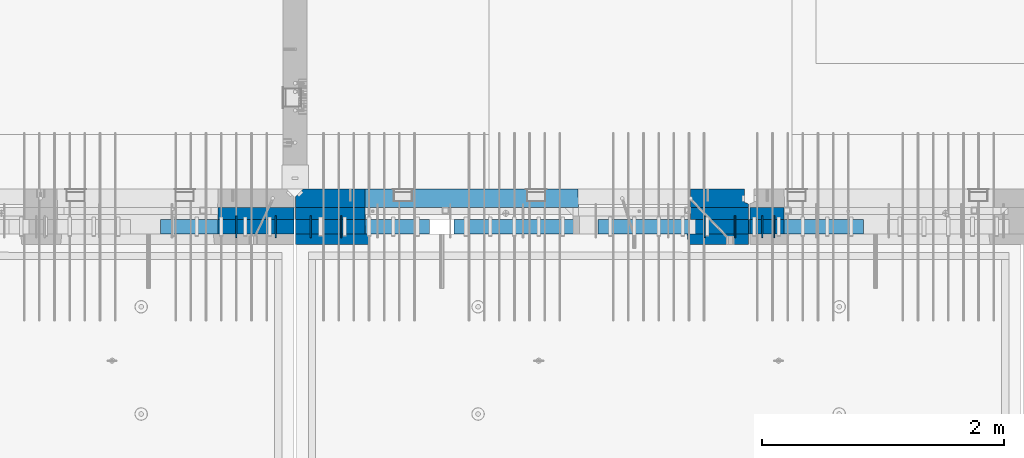
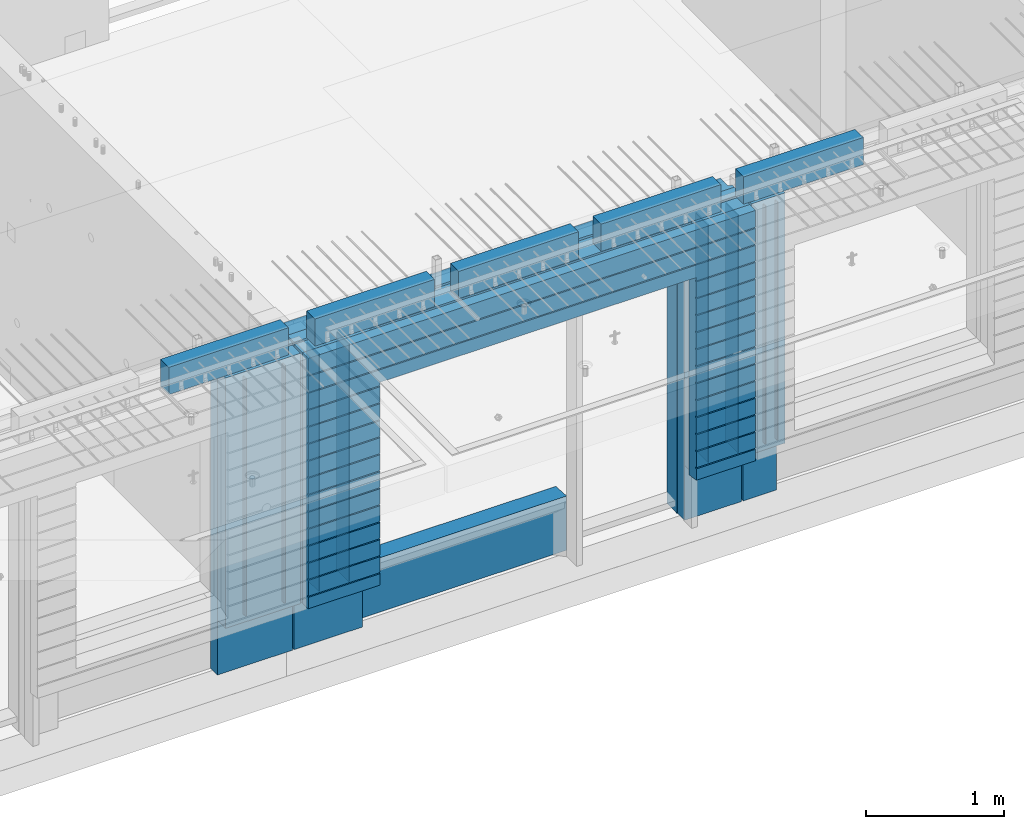
# One storey, part 211 of 325: 24 walls, 10 elements without a shape of their own.
"""IFC2X3 building model written with IfcOpenShell, lengths in millimetres."""

from ifc_helpers import new_model, si_unit, frame, origin_with_axes, place, context, subcontext, project, spatial, faceted_brep, material, type_object, element, aggregate, save


model = new_model("IFC2X3")

# Units and contexts
model_context = context("Model", 3, precision=1e-05, world=origin_with_axes())
body_context = subcontext(model_context, "Body", "Model", "MODEL_VIEW")
ifc_project = project(units=[si_unit("LENGTHUNIT", "METRE", prefix="MILLI"), si_unit("AREAUNIT", "SQUARE_METRE"), si_unit("VOLUMEUNIT", "CUBIC_METRE"), si_unit("MASSUNIT", "GRAM", prefix="KILO"), si_unit("TIMEUNIT", "SECOND"), si_unit("PLANEANGLEUNIT", "RADIAN"), si_unit("SOLIDANGLEUNIT", "STERADIAN"), si_unit("THERMODYNAMICTEMPERATUREUNIT", "DEGREE_CELSIUS"), si_unit("LUMINOUSINTENSITYUNIT", "LUMEN")], contexts=[model_context])

# Site, building, storey
site_placement = place(None, origin_with_axes())
site = spatial("IfcSite", under=ifc_project, at=site_placement, CompositionType="ELEMENT")
building_placement = place(site_placement, origin_with_axes())
building = spatial("IfcBuilding", under=site, at=building_placement, CompositionType="ELEMENT")
storey_placement = place(building_placement, origin_with_axes())
storey = spatial("IfcBuildingStorey", under=building, at=storey_placement, Name="1", CompositionType="ELEMENT", Elevation=0.0)

# Assemblies, wall
assembly_1_placement = place(storey_placement, origin_with_axes())
assembly_1 = element("IfcElementAssembly", 1, at=assembly_1_placement, inside=storey, AssemblyPlace="NOTDEFINED", PredefinedType="REINFORCEMENT_UNIT")
assembly_2_placement = place(assembly_1_placement, origin_with_axes())
assembly_2 = element("IfcElementAssembly", 2, at=assembly_2_placement, Name="Steel Assembly", AssemblyPlace="NOTDEFINED", PredefinedType="NOTDEFINED")
aggregate(assembly_1, [assembly_2])
ifc_material_1 = material()
wall_type_1 = type_object("IfcWallType", PredefinedType="NOTDEFINED")
wall_1_placement = place(assembly_2_placement, frame((20699.9998568133, 7690.00021946163, 84590.0), z_axis=(0.0, 0.0, 1.0), x_axis=(1.0, 0.0, 0.0)))
wall_1 = element("IfcWall", 3, at=wall_1_placement, type_object=wall_type_1, material=ifc_material_1, context=body_context, shape_type="Brep", body=[
    faceted_brep([(0.0, 60.0, -120.0), (0.0, 60.0, 120.0), (1000.0, 60.0, 120.0), (1000.0, 60.0, -120.0), (0.0, -60.0, 120.0), (1000.0, -60.0, 120.0), (0.0, -60.0, -120.0), (1000.0, -60.0, -120.0)], [[[0, 1, 2, 3]], [[1, 4, 5, 2]], [[4, 6, 7, 5]], [[6, 0, 3, 7]], [[5, 7, 3, 2]], [[6, 4, 1, 0]]]),
])
aggregate(assembly_2, [wall_1])

# Assemblies, walls
assembly_3_placement = place(storey_placement, origin_with_axes())
assembly_3 = element("IfcElementAssembly", 4, at=assembly_3_placement, inside=storey, AssemblyPlace="NOTDEFINED", PredefinedType="REINFORCEMENT_UNIT")
assembly_4_placement = place(assembly_3_placement, origin_with_axes())
assembly_4 = element("IfcElementAssembly", 5, at=assembly_4_placement, Name="Steel Assembly", AssemblyPlace="NOTDEFINED", PredefinedType="NOTDEFINED")
wall_2_placement = place(assembly_4_placement, frame((25499.9998568133, 7690.00021946163, 84590.0), z_axis=(0.0, 0.0, 1.0), x_axis=(1.0, 0.0, 0.0)))
wall_2 = element("IfcWall", 6, at=wall_2_placement, type_object=wall_type_1, material=ifc_material_1, context=body_context, shape_type="Brep", body=[
    faceted_brep([(0.0, 60.0, -120.0), (0.0, 60.0, 120.0), (1000.0, 60.0, 120.0), (1000.0, 60.0, -120.0), (0.0, -60.0, 120.0), (1000.0, -60.0, 120.0), (0.0, -60.0, -120.0), (1000.0, -60.0, -120.0)], [[[0, 1, 2, 3]], [[1, 4, 5, 2]], [[4, 6, 7, 5]], [[6, 0, 3, 7]], [[5, 7, 3, 2]], [[6, 4, 1, 0]]]),
])
aggregate(assembly_4, [wall_2])
assembly_5_placement = place(assembly_3_placement, origin_with_axes())
assembly_5 = element("IfcElementAssembly", 7, at=assembly_5_placement, Name="Steel Assembly", AssemblyPlace="NOTDEFINED", PredefinedType="NOTDEFINED")
wall_3_placement = place(assembly_5_placement, frame((24309.9998568133, 7690.00021946163, 84590.0), z_axis=(0.0, 0.0, 1.0), x_axis=(1.0, 0.0, 0.0)))
wall_3 = element("IfcWall", 8, at=wall_3_placement, type_object=wall_type_1, material=ifc_material_1, context=body_context, shape_type="Brep", body=[
    faceted_brep([(0.0, 60.0, -120.0), (0.0, 60.0, 120.0), (1000.0, 60.0, 120.0), (1000.0, 60.0, -120.0), (0.0, -60.0, 120.0), (1000.0, -60.0, 120.0), (0.0, -60.0, -120.0), (1000.0, -60.0, -120.0)], [[[0, 1, 2, 3]], [[1, 4, 5, 2]], [[4, 6, 7, 5]], [[6, 0, 3, 7]], [[5, 7, 3, 2]], [[6, 4, 1, 0]]]),
])
aggregate(assembly_5, [wall_3])
assembly_6_placement = place(assembly_3_placement, origin_with_axes())
assembly_6 = element("IfcElementAssembly", 9, at=assembly_6_placement, Name="Steel Assembly", AssemblyPlace="NOTDEFINED", PredefinedType="NOTDEFINED")
wall_4_placement = place(assembly_6_placement, frame((23119.9998568133, 7690.00021946163, 84590.0), z_axis=(0.0, 0.0, 1.0), x_axis=(1.0, 0.0, 0.0)))
wall_4 = element("IfcWall", 10, at=wall_4_placement, type_object=wall_type_1, material=ifc_material_1, context=body_context, shape_type="Brep", body=[
    faceted_brep([(0.0, 60.0, -120.0), (0.0, 60.0, 120.0), (1000.0, 60.0, 120.0), (1000.0, 60.0, -120.0), (0.0, -60.0, 120.0), (1000.0, -60.0, 120.0), (0.0, -60.0, -120.0), (1000.0, -60.0, -120.0)], [[[0, 1, 2, 3]], [[1, 4, 5, 2]], [[4, 6, 7, 5]], [[6, 0, 3, 7]], [[5, 7, 3, 2]], [[6, 4, 1, 0]]]),
])
aggregate(assembly_6, [wall_4])
assembly_7_placement = place(assembly_3_placement, origin_with_axes())
assembly_7 = element("IfcElementAssembly", 11, at=assembly_7_placement, Name="Steel Assembly", AssemblyPlace="NOTDEFINED", PredefinedType="NOTDEFINED")
aggregate(assembly_3, [assembly_7, assembly_6, assembly_5, assembly_4])
wall_5_placement = place(assembly_7_placement, frame((21919.9998568133, 7690.00021946163, 84590.0), z_axis=(0.0, 0.0, 1.0), x_axis=(1.0, 0.0, 0.0)))
wall_5 = element("IfcWall", 12, at=wall_5_placement, type_object=wall_type_1, material=ifc_material_1, context=body_context, shape_type="Brep", body=[
    faceted_brep([(0.0, 60.0, -120.0), (0.0, 60.0, 120.0), (1000.0, 60.0, 120.0), (1000.0, 60.0, -120.0), (0.0, -60.0, 120.0), (1000.0, -60.0, 120.0), (0.0, -60.0, -120.0), (1000.0, -60.0, -120.0)], [[[0, 1, 2, 3]], [[1, 4, 5, 2]], [[4, 6, 7, 5]], [[6, 0, 3, 7]], [[5, 7, 3, 2]], [[6, 4, 1, 0]]]),
])
aggregate(assembly_7, [wall_5])

# Assembly, wall
assembly_8_placement = place(storey_placement, origin_with_axes())
assembly_8 = element("IfcElementAssembly", 13, at=assembly_8_placement, inside=storey, AssemblyPlace="NOTDEFINED", PredefinedType="REINFORCEMENT_UNIT")
ifc_material_2 = material(Name="CONCRETE/C35/45")
wall_type_2 = type_object("IfcWallType", PredefinedType="NOTDEFINED")
wall_6_placement = place(assembly_8_placement, frame((25550.0, 7925.0, 83112.5), z_axis=(0.0, 0.0, 1.0), x_axis=(-1.0, 3.00000001838171e-08, 0.0)))
wall_6 = element("IfcWall", 14, at=wall_6_placement, type_object=wall_type_2, material=ifc_material_2, context=body_context, shape_type="Brep", body=[
    faceted_brep([(0.0, 75.0, 1357.5), (0.0, 75.0, -1357.5), (0.0, 45.0, -1357.5), (0.0, 45.0, 1357.5), (475.000517197066, -75.0, -1357.5), (478.846671043222, 75.0, -1357.5), (478.846671043219, 75.0, 948.653846153844), (475.000517197066, -75.0, 952.5), (32.5, -75.0, -1357.5), (32.5, 32.0, -1357.5), (32.5, -75.0, 1357.5), (32.5, 32.0, 1357.5), (3675.0, -75.0, 1357.5), (3735.0, -15.0, 1357.5), (3735.0, 75.0, 1357.5), (3735.0, 75.0, -1357.5), (3735.0, -15.0, -1357.5), (3675.0, -75.0, -1357.5), (1405.00051719707, -75.0, -1357.5), (1401.15436335091, 75.0, -1357.5), (1405.00051719707, -75.0, -882.5), (1401.15436335091, 75.0, -878.445945945947), (1334.05403802673, 75.0, 948.653846153844), (3160.9460816706, 75.0, -878.445945945947), (3160.9460816706, 75.0, 948.445945945947), (1401.15436335091, 75.0, 948.653846153844), (1330.00013572465, -75.0, 952.5), (1405.00051719707, -75.0, 952.5), (3165.00013572465, -75.0, -882.5), (3165.00013572465, -75.0, 952.5)], [[[0, 1, 2, 3]], [[4, 5, 6, 7]], [[8, 9, 2, 1, 5, 4]], [[10, 11, 9, 8]], [[3, 2, 9, 11]], [[10, 12, 13, 14, 0, 3, 11]], [[15, 14, 13, 16]], [[12, 17, 16, 13]], [[15, 16, 17, 18, 19]], [[19, 18, 20, 21]], [[22, 6, 5, 1, 0, 14, 15, 19, 21, 23, 24, 25]], [[26, 7, 6, 22, 25, 27]], [[28, 20, 18, 17, 12, 10, 8, 4, 7, 26, 27, 29]], [[25, 24, 29, 27]], [[23, 28, 29, 24]], [[21, 20, 28, 23]]]),
])

# Assembly, walls
assembly_9_placement = place(storey_placement, origin_with_axes())
assembly_9 = element("IfcElementAssembly", 15, at=assembly_9_placement, inside=storey, AssemblyPlace="NOTDEFINED", PredefinedType="REINFORCEMENT_UNIT")
ifc_material_3 = material(Name="Undefined")
wall_type_3 = type_object("IfcWallType", PredefinedType="NOTDEFINED")
wall_7_placement = place(assembly_9_placement, frame((25665.0, 7780.0, 83365.0), z_axis=(0.0, 0.0, 1.0), x_axis=(0.0, -1.0, 0.0)))
wall_7 = element("IfcWall", 16, at=wall_7_placement, type_object=wall_type_3, material=ifc_material_3, Name="(PD)", context=body_context, shape_type="Brep", body=[
    faceted_brep([(0.0, 5.0, -1050.0), (0.0, 5.0, 1050.0), (180.0, 5.0, 1050.0), (180.0, 5.0, -1050.0), (0.0, -5.0, 1050.0), (180.0, -5.0, 1050.0), (0.0, -5.0, -1050.0), (180.0, -5.0, -1050.0)], [[[0, 1, 2, 3]], [[1, 4, 5, 2]], [[4, 6, 7, 5]], [[6, 0, 3, 7]], [[5, 7, 3, 2]], [[6, 4, 1, 0]]]),
])
wall_8_placement = place(assembly_9_placement, frame((25765.0, 7780.0, 83365.0), z_axis=(0.0, 0.0, 1.0), x_axis=(0.0, -1.0, 0.0)))
wall_8 = element("IfcWall", 17, at=wall_8_placement, type_object=wall_type_3, material=ifc_material_3, Name="(PD)", context=body_context, shape_type="Brep", body=[
    faceted_brep([(0.0, 5.0, -1050.0), (0.0, 5.0, 1050.0), (180.0, 5.0, 1050.0), (180.0, 5.0, -1050.0), (0.0, -5.0, 1050.0), (180.0, -5.0, 1050.0), (0.0, -5.0, -1050.0), (180.0, -5.0, -1050.0)], [[[0, 1, 2, 3]], [[1, 4, 5, 2]], [[4, 6, 7, 5]], [[6, 0, 3, 7]], [[5, 7, 3, 2]], [[6, 4, 1, 0]]]),
])

assembly_10_placement = place(storey_placement, origin_with_axes())
assembly_10 = element("IfcElementAssembly", 18, at=assembly_10_placement, inside=storey, AssemblyPlace="NOTDEFINED", PredefinedType="REINFORCEMENT_UNIT")
wall_9_placement = place(assembly_10_placement, frame((21325.0, 7780.0, 83365.0), z_axis=(0.0, 0.0, 1.0), x_axis=(0.0, -1.0, 0.0)))
wall_9 = element("IfcWall", 19, at=wall_9_placement, type_object=wall_type_3, material=ifc_material_3, Name="(PD)", context=body_context, shape_type="Brep", body=[
    faceted_brep([(0.0, 5.0, -1050.0), (0.0, 5.0, 1050.0), (180.0, 5.0, 1050.0), (180.0, 5.0, -1050.0), (0.0, -5.0, 1050.0), (180.0, -5.0, 1050.0), (0.0, -5.0, -1050.0), (180.0, -5.0, -1050.0)], [[[0, 1, 2, 3]], [[1, 4, 5, 2]], [[4, 6, 7, 5]], [[6, 0, 3, 7]], [[5, 7, 3, 2]], [[6, 4, 1, 0]]]),
])
wall_10_placement = place(assembly_10_placement, frame((21650.0, 7780.0, 83365.0), z_axis=(0.0, 0.0, 1.0), x_axis=(0.0, -1.0, 0.0)))
wall_10 = element("IfcWall", 20, at=wall_10_placement, type_object=wall_type_3, material=ifc_material_3, Name="(PD)", context=body_context, shape_type="Brep", body=[
    faceted_brep([(0.0, 5.0, -1050.0), (0.0, 5.0, 1050.0), (180.0, 5.0, 1050.0), (180.0, 5.0, -1050.0), (0.0, -5.0, 1050.0), (180.0, -5.0, 1050.0), (0.0, -5.0, -1050.0), (180.0, -5.0, -1050.0)], [[[0, 1, 2, 3]], [[1, 4, 5, 2]], [[4, 6, 7, 5]], [[6, 0, 3, 7]], [[5, 7, 3, 2]], [[6, 4, 1, 0]]]),
])

# Wall
wall_11_placement = place(assembly_8_placement, frame((25190.0, 7780.0, 83365.0), z_axis=(0.0, 0.0, 1.0), x_axis=(0.0, -1.0, 0.0)))
wall_11 = element("IfcWall", 21, at=wall_11_placement, type_object=wall_type_3, material=ifc_material_3, Name="(PD)", context=body_context, shape_type="Brep", body=[
    faceted_brep([(0.0, 5.0, -1050.0), (0.0, 5.0, 1050.0), (180.0, 5.0, 1050.0), (180.0, 5.0, -1050.0), (0.0, -5.0, 1050.0), (180.0, -5.0, 1050.0), (0.0, -5.0, -1050.0), (180.0, -5.0, -1050.0)], [[[0, 1, 2, 3]], [[1, 4, 5, 2]], [[4, 6, 7, 5]], [[6, 0, 3, 7]], [[5, 7, 3, 2]], [[6, 4, 1, 0]]]),
])

wall_12_placement = place(assembly_8_placement, frame((22190.0, 7780.0, 83365.0), z_axis=(0.0, 0.0, 1.0), x_axis=(0.0, -1.0, 0.0)))
wall_12 = element("IfcWall", 22, at=wall_12_placement, type_object=wall_type_3, material=ifc_material_3, Name="(PD)", context=body_context, shape_type="Brep", body=[
    faceted_brep([(0.0, 5.0, -1050.0), (0.0, 5.0, 1050.0), (180.0, 5.0, 1050.0), (180.0, 5.0, -1050.0), (0.0, -5.0, 1050.0), (180.0, -5.0, 1050.0), (0.0, -5.0, -1050.0), (180.0, -5.0, -1050.0)], [[[0, 1, 2, 3]], [[1, 4, 5, 2]], [[4, 6, 7, 5]], [[6, 0, 3, 7]], [[5, 7, 3, 2]], [[6, 4, 1, 0]]]),
])

wall_13_placement = place(assembly_8_placement, frame((21940.0, 7780.0, 83365.0), z_axis=(0.0, 0.0, 1.0), x_axis=(0.0, -1.0, 0.0)))
wall_13 = element("IfcWall", 23, at=wall_13_placement, type_object=wall_type_3, material=ifc_material_3, Name="(PD)", context=body_context, shape_type="Brep", body=[
    faceted_brep([(0.0, 5.0, -1050.0), (0.0, 5.0, 1050.0), (180.0, 5.0, 1050.0), (180.0, 5.0, -1050.0), (0.0, -5.0, 1050.0), (180.0, -5.0, 1050.0), (0.0, -5.0, -1050.0), (180.0, -5.0, -1050.0)], [[[0, 1, 2, 3]], [[1, 4, 5, 2]], [[4, 6, 7, 5]], [[6, 0, 3, 7]], [[5, 7, 3, 2]], [[6, 4, 1, 0]]]),
])

wall_14_placement = place(assembly_8_placement, frame((25440.0, 7780.0, 83365.0), z_axis=(0.0, 0.0, 1.0), x_axis=(0.0, -1.0, 0.0)))
wall_14 = element("IfcWall", 24, at=wall_14_placement, type_object=wall_type_3, material=ifc_material_3, Name="(PD)", context=body_context, shape_type="Brep", body=[
    faceted_brep([(0.0, 5.0, -1050.0), (0.0, 5.0, 1050.0), (180.0, 5.0, 1050.0), (180.0, 5.0, -1050.0), (0.0, -5.0, 1050.0), (180.0, -5.0, 1050.0), (0.0, -5.0, -1050.0), (180.0, -5.0, -1050.0)], [[[0, 1, 2, 3]], [[1, 4, 5, 2]], [[4, 6, 7, 5]], [[6, 0, 3, 7]], [[5, 7, 3, 2]], [[6, 4, 1, 0]]]),
])

wall_type_4 = type_object("IfcWallType", PredefinedType="NOTDEFINED")
wall_15_placement = place(assembly_10_placement, frame((21800.0000381475, 7800.0, 83112.5), z_axis=(0.0, 0.0, 1.0), x_axis=(-1.0, 3.00000001838171e-08, 0.0)))
wall_15 = element("IfcWall", 25, at=wall_15_placement, type_object=wall_type_4, material=ifc_material_2, context=body_context, shape_type="Brep", body=[
    faceted_brep([(0.0, 50.0, -1357.5), (0.0, 50.0, 1357.5), (625.001908754726, 50.0, 1357.5), (625.001908754726, 50.0, -1357.5), (0.0, -50.0, 1357.5), (625.001908754726, -50.0, 1357.5), (0.0, -50.0, -1357.5), (625.001908754726, -50.0, -1357.5)], [[[0, 1, 2, 3]], [[1, 4, 5, 2]], [[4, 6, 7, 5]], [[6, 0, 3, 7]], [[5, 7, 3, 2]], [[6, 4, 1, 0]]]),
])

wall_16_placement = place(assembly_8_placement, frame((22385.0000381475, 7800.00011629906, 83112.5), z_axis=(0.0, 0.0, 1.0), x_axis=(-1.0, 3.00000001838171e-08, 0.0)))
wall_16 = element("IfcWall", 26, at=wall_16_placement, type_object=wall_type_4, material=ifc_material_2, context=body_context, shape_type="Brep", body=[
    faceted_brep([(0.0, 50.0, -1357.5), (0.0, 50.0, 1357.5), (570.001908754726, 50.0, 1357.5), (570.001908754726, 50.0, -1357.5), (0.0, -50.0, 1357.5), (570.001908754726, -50.0, 1357.5), (0.0, -50.0, -1357.5), (570.001908754726, -50.0, -1357.5)], [[[0, 1, 2, 3]], [[1, 4, 5, 2]], [[4, 6, 7, 5]], [[6, 0, 3, 7]], [[5, 7, 3, 2]], [[6, 4, 1, 0]]]),
])

wall_17_placement = place(assembly_8_placement, frame((25550.0000381475, 7800.00011629906, 83112.5), z_axis=(0.0, 0.0, 1.0), x_axis=(-1.0, 3.00000001838171e-08, 0.0)))
wall_17 = element("IfcWall", 27, at=wall_17_placement, type_object=wall_type_4, material=ifc_material_2, context=body_context, shape_type="Brep", body=[
    faceted_brep([(0.0, 50.0, -1357.5), (0.0, 50.0, 1357.5), (475.001908754726, 50.0, 1357.5), (475.001908754726, 50.0, -1357.5), (0.0, -50.0, 1357.5), (475.001908754726, -50.0, 1357.5), (0.0, -50.0, -1357.5), (475.001908754726, -50.0, -1357.5)], [[[0, 1, 2, 3]], [[1, 4, 5, 2]], [[4, 6, 7, 5]], [[6, 0, 3, 7]], [[5, 7, 3, 2]], [[6, 4, 1, 0]]]),
])

wall_18_placement = place(assembly_9_placement, frame((25845.0000381475, 7800.0, 83112.5), z_axis=(0.0, 0.0, 1.0), x_axis=(-1.0, 3.00000001838171e-08, 0.0)))
wall_18 = element("IfcWall", 28, at=wall_18_placement, type_object=wall_type_4, material=ifc_material_2, context=body_context, shape_type="Brep", body=[
    faceted_brep([(0.0, 50.0, -1357.5), (0.0, 50.0, 1357.5), (280.001908754726, 50.0, 1357.5), (280.001908754726, 50.0, -1357.5), (0.0, -50.0, 1357.5), (280.001908754726, -50.0, 1357.5), (0.0, -50.0, -1357.5), (280.001908754726, -50.0, -1357.5)], [[[0, 1, 2, 3]], [[1, 4, 5, 2]], [[4, 6, 7, 5]], [[6, 0, 3, 7]], [[5, 7, 3, 2]], [[6, 4, 1, 0]]]),
])

ifc_material_4 = material(Name="SPU")
wall_type_5 = type_object("IfcWallType", PredefinedType="NOTDEFINED")
wall_19_placement = place(assembly_10_placement, frame((21800.0000381475, 7690.0, 83102.5), z_axis=(0.0, 0.0, 1.0), x_axis=(-1.0, 3.00000001838171e-08, 0.0)))
wall_19 = element("IfcWall", 29, at=wall_19_placement, type_object=wall_type_5, material=ifc_material_4, context=body_context, shape_type="Brep", body=[
    faceted_brep([(0.0, 60.0, 1347.5), (0.0, -60.0, 1347.5), (625.001908754726, -60.0, 1347.5), (625.001908754726, 60.0, 1347.5), (0.0, -60.0, -862.5), (625.001908754726, -60.0, -862.5), (625.001908754726, 60.0, -862.5), (0.0, 60.0, -862.5)], [[[0, 1, 2, 3]], [[2, 1, 4, 5]], [[3, 2, 5, 6]], [[0, 3, 6, 7]], [[1, 0, 7, 4]], [[6, 5, 4, 7]]]),
])

aggregate(assembly_10, [wall_19, wall_15, wall_9, wall_10])

wall_20_placement = place(assembly_8_placement, frame((22385.0000381475, 7690.00011629906, 83102.5), z_axis=(0.0, 0.0, 1.0), x_axis=(-1.0, 3.00000001838171e-08, 0.0)))
wall_20 = element("IfcWall", 30, at=wall_20_placement, type_object=wall_type_5, material=ifc_material_4, context=body_context, shape_type="Brep", body=[
    faceted_brep([(0.0, 60.0, 1347.5), (0.0, -60.0, 1347.5), (570.001908754726, -60.0, 1347.5), (570.001908754726, 60.0, 1347.5), (0.0, -60.0, -862.5), (570.001908754726, -60.0, -862.5), (570.001908754726, 60.0, -862.5), (0.0, 60.0, -862.5)], [[[0, 1, 2, 3]], [[2, 1, 4, 5]], [[3, 2, 5, 6]], [[0, 3, 6, 7]], [[1, 0, 7, 4]], [[6, 5, 4, 7]]]),
])

wall_21_placement = place(assembly_8_placement, frame((25550.0000381475, 7690.00011629906, 83102.5), z_axis=(0.0, 0.0, 1.0), x_axis=(-1.0, 3.00000001838171e-08, 0.0)))
wall_21 = element("IfcWall", 31, at=wall_21_placement, type_object=wall_type_5, material=ifc_material_4, context=body_context, shape_type="Brep", body=[
    faceted_brep([(0.0, 60.0, 1347.5), (0.0, -60.0, 1347.5), (475.001908754726, -60.0, 1347.5), (475.001908754726, 60.0, 1347.5), (0.0, -60.0, -862.5), (475.001908754726, -60.0, -862.5), (475.001908754726, 60.0, -862.5), (0.0, 60.0, -862.5)], [[[0, 1, 2, 3]], [[2, 1, 4, 5]], [[3, 2, 5, 6]], [[0, 3, 6, 7]], [[1, 0, 7, 4]], [[6, 5, 4, 7]]]),
])

wall_22_placement = place(assembly_9_placement, frame((25845.0000381475, 7690.0, 83102.5), z_axis=(0.0, 0.0, 1.0), x_axis=(-1.0, 3.00000001838171e-08, 0.0)))
wall_22 = element("IfcWall", 32, at=wall_22_placement, type_object=wall_type_5, material=ifc_material_4, context=body_context, shape_type="Brep", body=[
    faceted_brep([(0.0, 60.0, 1347.5), (0.0, -60.0, 1347.5), (280.001908754726, -60.0, 1347.5), (280.001908754726, 60.0, 1347.5), (0.0, -60.0, -862.5), (280.001908754726, -60.0, -862.5), (280.001908754726, 60.0, -862.5), (0.0, 60.0, -862.5)], [[[0, 1, 2, 3]], [[2, 1, 4, 5]], [[3, 2, 5, 6]], [[0, 3, 6, 7]], [[1, 0, 7, 4]], [[6, 5, 4, 7]]]),
])

aggregate(assembly_9, [wall_22, wall_7, wall_8, wall_18])

ifc_material_5 = material(Name="CONCRETE/C30/37")
wall_type_6 = type_object("IfcWallType", PredefinedType="NOTDEFINED")
wall_23_placement = place(assembly_8_placement, frame((25550.0, 7587.5, 83102.5), z_axis=(0.0, 0.0, 1.0), x_axis=(-1.0, 3.00000001838171e-08, 0.0)))
wall_23 = element("IfcWall", 33, at=wall_23_placement, type_object=wall_type_6, material=ifc_material_5, context=body_context, shape_type="Brep", body=[
    faceted_brep([(0.0, 42.5, -762.000000055225), (0.0, 32.4999992517696, -760.000000000757), (496.175125128244, 32.4999992517696, -760.000000000757), (494.998458373539, 42.5, -762.000000055225), (0.0, 32.4999991137702, -749.99999959956), (496.175125144484, 32.4999991137702, -749.99999959956), (0.0, 42.5, -748.00000011074), (494.998458373539, 42.5, -748.00000011074), (0.0, 42.5, -612.000000055239), (494.998458373539, 42.5, -612.000000055239), (0.0, 32.4999992522971, -610.000000000771), (496.175125128182, 32.4999992522971, -610.000000000771), (0.0, 32.4999991143004, -599.99999959956), (496.175125144422, 32.4999991143004, -599.99999959956), (0.0, 42.5, -598.000000110755), (494.998458373539, 42.5, -598.000000110755), (0.0, 42.5, -462.000000055239), (494.998458373539, 42.5, -462.000000055239), (0.0, 32.4999992528365, -460.000000000771), (496.17512512812, 32.4999992528365, -460.000000000771), (0.0, 32.4999991148252, -449.999999599575), (496.17512514436, 32.4999991148252, -449.999999599575), (0.0, 42.5, -448.000000110755), (494.998458373539, 42.5, -448.000000110755), (0.0, 42.5, -312.000000055254), (494.998458373539, 42.5, -312.000000055254), (0.0, 32.4999992533649, -310.000000000786), (496.175125128058, 32.4999992533649, -310.000000000786), (0.0, 32.4999991153618, -299.99999959959), (496.175125144298, 32.4999991153618, -299.99999959959), (0.0, 42.5, -298.000000110769), (494.998458373539, 42.5, -298.000000110769), (0.0, 42.5, -162.000000055239), (494.998458373539, 42.5, -162.000000055239), (0.0, 32.4999992538978, -160.000000000757), (496.175125127997, 32.4999992538978, -160.000000000757), (0.0, 32.4999991158993, -149.99999959956), (496.175125144237, 32.4999991158993, -149.99999959956), (0.0, 42.5, -148.000000110755), (494.998458373539, 42.5, -148.000000110755), (0.0, 42.5, -12.0000000552391), (494.998458373539, 42.5, -12.0000000552391), (0.0, 32.4999992538942, -10.0000000007858), (496.175125127997, 32.4999992538942, -10.0000000007858), (0.0, 32.4999991158911, 4.00425051338971e-07), (496.175125144237, 32.4999991158911, 4.00425051338971e-07), (0.0, 42.5, 1.99999988924537), (494.998458373539, 42.5, 1.99999988924537), (0.0, 42.5, 137.999999944775), (494.998458373539, 42.5, 137.999999944775), (0.0, 32.4999992500552, 139.999999999229), (496.175125128448, 32.4999992500552, 139.999999999229), (0.0, 32.4999991120549, 150.00000040044), (496.175125144684, 32.4999991120549, 150.00000040044), (0.0, 42.5, 151.99999988926), (494.998458373539, 42.5, 151.99999988926), (0.0, 42.5, 287.999999944761), (494.998458373539, 42.5, 287.999999944761), (-3.63797880709171e-12, 32.4999992500416, 289.999999999229), (496.175125128451, 32.4999992500416, 289.999999999229), (-3.63797880709171e-12, 32.4999991120458, 300.00000040044), (496.175125144688, 32.4999991120458, 300.00000040044), (0.0, 42.5, 301.999999889245), (494.998458373539, 42.5, 301.999999889245), (0.0, 42.5, 437.999999944746), (494.998458373539, 42.5, 437.999999944746), (0.0, 32.4999992500289, 439.999999999214), (496.175125128451, 32.4999992500289, 439.999999999214), (0.0, 32.4999991120258, 450.000000400411), (496.175125144688, 32.4999991120258, 450.000000400411), (0.0, 42.5, 451.999999889231), (494.998458373539, 42.5, 451.999999889231), (0.0, 42.5, 587.999999944775), (494.998458373539, 42.5, 587.999999944775), (0.0, 32.499999250017, 589.999999999229), (496.175125128455, 32.499999250017, 589.999999999229), (0.0, 32.4999991120094, 600.00000040044), (496.175125144691, 32.4999991120094, 600.00000040044), (0.0, 42.5, 601.99999988926), (494.998458373539, 42.5, 601.99999988926), (0.0, 42.5, 737.999999944761), (494.998458373539, 42.5, 737.999999944761), (0.0, 32.4999992499997, 739.999999999229), (496.175125128455, 32.4999992499997, 739.999999999229), (0.0, 32.4999991120039, 750.00000040044), (496.175125144691, 32.4999991120039, 750.00000040044), (0.0, 42.5, 751.999999889245), (494.998458373539, 42.5, 751.999999889245), (0.0, 42.5, 887.999999944761), (494.998458373539, 42.5, 887.999999944761), (3.63797880709171e-12, 32.4999992499852, 889.999999999229), (496.175125128459, 32.4999992499852, 889.999999999229), (3.63797880709171e-12, 32.4999991119857, 900.000000400425), (496.175125144691, 32.4999991119857, 900.000000400425), (0.0, 42.5, 901.999999889245), (494.998458373539, 42.5, 901.999999889245), (0.0, 42.5, 1347.5), (3735.0, 42.5, 1347.5), (3735.0, 42.5, 1201.99999988925), (0.0, 42.5, 1201.99999988925), (3735.0, 32.4999991119576, 1200.00000040043), (-3.63797880709171e-12, 32.4999991119576, 1200.00000040043), (3735.0, 32.499999249967, 1189.99999999923), (-3.63797880709171e-12, 32.499999249967, 1189.99999999923), (3735.0, 42.5, 1187.99999994476), (0.0, 42.5, 1187.99999994476), (3735.0, 42.5, 1051.99999988925), (0.0, 42.5, 1051.99999988925), (3735.0, 32.4999991119639, 1050.00000040043), (3.63797880709171e-12, 32.4999991119639, 1050.00000040043), (3735.0, 32.4999992499725, 1039.99999999921), (3.63797880709171e-12, 32.4999992499725, 1039.99999999921), (3735.0, 42.5, 1037.99999994476), (0.0, 42.5, 1037.99999994476), (505.000517197066, 42.5, 927.5), (1360.00013572465, 42.5, 927.5), (1370.00013572465, 42.5, 927.5), (1375.00051719707, 42.5, 927.5), (1384.99845837354, 42.5, 927.5), (1374.99679170687, -42.5, 932.5), (1370.00013572465, -42.5, 932.502857142856), (505.000125040206, -42.5, 932.502857142856), (494.998458373539, 42.5, 927.5), (3125.00013572465, 42.5, 927.5), (3135.00013572465, 42.5, 927.5), (3125.00013572465, -42.5, 932.5), (3735.0, 42.5, 901.999999889245), (3135.00013572465, 42.5, 901.999999889245), (3735.0, 32.4999991119857, 900.000000400425), (3133.82366503195, 32.4999991119857, 900.000000400425), (3735.0, 32.4999992499852, 889.999999999229), (3133.82366504818, 32.4999992499852, 889.999999999229), (3735.0, 42.5, 887.999999944761), (3135.00013572465, 42.5, 887.999999944761), (3735.0, 42.5, 751.999999889245), (3135.00013572465, 42.5, 751.999999889245), (3735.0, 32.4999991120039, 750.00000040044), (3133.82366503195, 32.4999991120039, 750.00000040044), (3735.0, 32.4999992499997, 739.999999999229), (3133.82366504818, 32.4999992499997, 739.999999999229), (3735.0, 42.5, 737.999999944761), (3135.00013572465, 42.5, 737.999999944761), (3735.0, 42.5, 601.99999988926), (3135.00013572465, 42.5, 601.99999988926), (3735.0, 32.4999991120094, 600.00000040044), (3133.82366503195, 32.4999991120094, 600.00000040044), (3735.0, 32.499999250017, 589.999999999229), (3133.82366504818, 32.499999250017, 589.999999999229), (3735.0, 42.5, 587.999999944775), (3135.00013572465, 42.5, 587.999999944775), (3735.0, 42.5, 451.999999889231), (3135.00013572465, 42.5, 451.999999889231), (3735.0, 32.4999991120258, 450.000000400411), (3133.82366503195, 32.4999991120258, 450.000000400411), (3735.0, 32.4999992500289, 439.999999999214), (3133.82366504818, 32.4999992500289, 439.999999999214), (3735.0, 42.5, 437.999999944746), (3135.00013572465, 42.5, 437.999999944746), (3735.0, 42.5, 301.999999889245), (3135.00013572465, 42.5, 301.999999889245), (3735.0, 32.4999991120458, 300.00000040044), (3133.82366503195, 32.4999991120458, 300.00000040044), (3735.0, 32.4999992500416, 289.999999999229), (3133.82366504819, 32.4999992500416, 289.999999999229), (3735.0, 42.5, 287.999999944761), (3135.00013572465, 42.5, 287.999999944761), (3735.0, 42.5, 151.99999988926), (3135.00013572465, 42.5, 151.99999988926), (3735.0, 32.4999991120549, 150.00000040044), (3133.82366503195, 32.4999991120549, 150.00000040044), (3735.0, 32.4999992500552, 139.999999999229), (3133.82366504819, 32.4999992500552, 139.999999999229), (3735.0, 42.5, 137.999999944775), (3135.00013572465, 42.5, 137.999999944775), (3735.0, 42.5, 1.99999988924537), (3135.00013572465, 42.5, 1.99999988924537), (3735.0, 32.4999991158911, 4.00425051338971e-07), (3133.8236650324, 32.4999991158911, 4.00425051338971e-07), (3735.0, 32.4999992538942, -10.0000000007858), (3133.82366504864, 32.4999992538942, -10.0000000007858), (3735.0, 42.5, -12.0000000552391), (3135.00013572465, 42.5, -12.0000000552391), (3735.0, 42.5, -148.000000110755), (3135.00013572465, 42.5, -148.000000110755), (3735.0, 32.4999991158993, -149.99999959956), (3133.8236650324, 32.4999991158993, -149.99999959956), (3735.0, 32.4999992538978, -160.000000000757), (3133.82366504864, 32.4999992538978, -160.000000000757), (3735.0, 42.5, -162.000000055239), (3135.00013572465, 42.5, -162.000000055239), (3735.0, 42.5, -298.000000110769), (3135.00013572465, 42.5, -298.000000110769), (3735.0, 32.4999991153618, -299.99999959959), (3133.82366503234, 32.4999991153618, -299.99999959959), (3735.0, 32.4999992533649, -310.000000000786), (3133.82366504858, 32.4999992533649, -310.000000000786), (3735.0, 42.5, -312.000000055254), (3135.00013572465, 42.5, -312.000000055254), (3735.0, 42.5, -448.000000110755), (3135.00013572465, 42.5, -448.000000110755), (3735.0, 32.4999991148252, -449.999999599575), (3133.82366503228, 32.4999991148252, -449.999999599575), (3735.0, 32.4999992528365, -460.000000000771), (3133.82366504852, 32.4999992528365, -460.000000000771), (3735.0, 42.5, -462.000000055239), (3135.00013572465, 42.5, -462.000000055239), (3735.0, 42.5, -598.000000110755), (3135.00013572465, 42.5, -598.000000110755), (3735.0, 32.4999991143004, -599.99999959956), (3133.82366503222, 32.4999991143004, -599.99999959956), (3735.0, 32.4999992522971, -610.000000000771), (3133.82366504845, 32.4999992522971, -610.000000000771), (3735.0, 42.5, -612.000000055239), (3135.00013572465, 42.5, -612.000000055239), (3735.0, 42.5, -748.00000011074), (3135.00013572465, 42.5, -748.00000011074), (3735.0, 32.4999991137702, -749.99999959956), (3133.82366503216, 32.4999991137702, -749.99999959956), (3735.0, 32.4999992517696, -760.000000000757), (3133.82366504839, 32.4999992517696, -760.000000000757), (3735.0, 42.5, -762.000000055225), (3135.00013572465, 42.5, -762.000000055225), (3735.0, 42.5, -862.5), (3135.00013572465, 42.5, -862.5), (3125.00013572465, -42.5, 927.5), (3125.00013572465, -42.5, -862.5), (3735.0, -42.5, -862.5), (3735.0, -42.5, 1347.5), (0.0, -42.5, 1347.5), (505.000125040206, -42.5, 927.5), (0.0, -42.5, -862.5), (505.000125040202, -42.5, -862.5), (494.998458373539, 42.5, -862.5), (0.0, 42.5, -862.5)], [[[0, 1, 2, 3]], [[1, 4, 5, 2]], [[4, 6, 7, 5]], [[6, 8, 9, 7]], [[8, 10, 11, 9]], [[10, 12, 13, 11]], [[12, 14, 15, 13]], [[14, 16, 17, 15]], [[16, 18, 19, 17]], [[18, 20, 21, 19]], [[20, 22, 23, 21]], [[22, 24, 25, 23]], [[24, 26, 27, 25]], [[26, 28, 29, 27]], [[28, 30, 31, 29]], [[30, 32, 33, 31]], [[32, 34, 35, 33]], [[34, 36, 37, 35]], [[36, 38, 39, 37]], [[38, 40, 41, 39]], [[40, 42, 43, 41]], [[42, 44, 45, 43]], [[44, 46, 47, 45]], [[46, 48, 49, 47]], [[48, 50, 51, 49]], [[50, 52, 53, 51]], [[52, 54, 55, 53]], [[54, 56, 57, 55]], [[56, 58, 59, 57]], [[58, 60, 61, 59]], [[60, 62, 63, 61]], [[62, 64, 65, 63]], [[64, 66, 67, 65]], [[66, 68, 69, 67]], [[68, 70, 71, 69]], [[70, 72, 73, 71]], [[72, 74, 75, 73]], [[74, 76, 77, 75]], [[76, 78, 79, 77]], [[78, 80, 81, 79]], [[80, 82, 83, 81]], [[82, 84, 85, 83]], [[84, 86, 87, 85]], [[86, 88, 89, 87]], [[88, 90, 91, 89]], [[90, 92, 93, 91]], [[92, 94, 95, 93]], [[96, 97, 98, 99]], [[99, 98, 100, 101]], [[101, 100, 102, 103]], [[103, 102, 104, 105]], [[106, 107, 105, 104]], [[107, 106, 108, 109]], [[109, 108, 110, 111]], [[111, 110, 112, 113]], [[114, 115, 116, 117, 118, 119, 120, 121, 122]], [[119, 118, 123, 124, 125]], [[118, 117, 116, 115, 114, 122, 95, 94, 113, 112, 126, 127, 124, 123]], [[126, 128, 129, 127]], [[128, 130, 131, 129]], [[130, 132, 133, 131]], [[132, 134, 135, 133]], [[134, 136, 137, 135]], [[136, 138, 139, 137]], [[138, 140, 141, 139]], [[140, 142, 143, 141]], [[142, 144, 145, 143]], [[144, 146, 147, 145]], [[146, 148, 149, 147]], [[148, 150, 151, 149]], [[150, 152, 153, 151]], [[152, 154, 155, 153]], [[154, 156, 157, 155]], [[156, 158, 159, 157]], [[158, 160, 161, 159]], [[160, 162, 163, 161]], [[162, 164, 165, 163]], [[164, 166, 167, 165]], [[166, 168, 169, 167]], [[168, 170, 171, 169]], [[170, 172, 173, 171]], [[172, 174, 175, 173]], [[174, 176, 177, 175]], [[176, 178, 179, 177]], [[178, 180, 181, 179]], [[180, 182, 183, 181]], [[182, 184, 185, 183]], [[184, 186, 187, 185]], [[186, 188, 189, 187]], [[188, 190, 191, 189]], [[190, 192, 193, 191]], [[192, 194, 195, 193]], [[194, 196, 197, 195]], [[196, 198, 199, 197]], [[198, 200, 201, 199]], [[200, 202, 203, 201]], [[202, 204, 205, 203]], [[204, 206, 207, 205]], [[206, 208, 209, 207]], [[208, 210, 211, 209]], [[210, 212, 213, 211]], [[212, 214, 215, 213]], [[214, 216, 217, 215]], [[216, 218, 219, 217]], [[218, 220, 221, 219]], [[221, 220, 222, 223]], [[224, 125, 124, 127, 129, 131, 133, 135, 137, 139, 141, 143, 145, 147, 149, 151, 153, 155, 157, 159, 161, 163, 165, 167, 169, 171, 173, 175, 177, 179, 181, 183, 185, 187, 189, 191, 193, 195, 197, 199, 201, 203, 205, 207, 209, 211, 213, 215, 217, 219, 221, 223, 225]], [[222, 226, 225, 223]], [[220, 218, 216, 214, 212, 210, 208, 206, 204, 202, 200, 198, 196, 194, 192, 190, 188, 186, 184, 182, 180, 178, 176, 174, 172, 170, 168, 166, 164, 162, 160, 158, 156, 154, 152, 150, 148, 146, 144, 142, 140, 138, 136, 134, 132, 130, 128, 126, 112, 110, 108, 106, 104, 102, 100, 98, 97, 227, 226, 222]], [[96, 228, 227, 97]], [[229, 121, 120, 119, 125, 224, 225, 226, 227, 228, 230, 231]], [[3, 2, 5, 7, 9, 11, 13, 15, 17, 19, 21, 23, 25, 27, 29, 31, 33, 35, 37, 39, 41, 43, 45, 47, 49, 51, 53, 55, 57, 59, 61, 63, 65, 67, 69, 71, 73, 75, 77, 79, 81, 83, 85, 87, 89, 91, 93, 95, 122, 121, 229, 231, 232]], [[0, 3, 232, 233]], [[228, 96, 99, 101, 103, 105, 107, 109, 111, 113, 94, 92, 90, 88, 86, 84, 82, 80, 78, 76, 74, 72, 70, 68, 66, 64, 62, 60, 58, 56, 54, 52, 50, 48, 46, 44, 42, 40, 38, 36, 34, 32, 30, 28, 26, 24, 22, 20, 18, 16, 14, 12, 10, 8, 6, 4, 1, 0, 233, 230]], [[232, 231, 230, 233]]]),
])

ifc_material_6 = material(Name="COS5gt")
wall_type_7 = type_object("IfcWallType", PredefinedType="NOTDEFINED")
wall_24_placement = place(assembly_8_placement, frame((25075.0, 7740.0, 83102.5), z_axis=(0.0, 0.0, 1.0), x_axis=(-1.0, 3.00000001838171e-08, 0.0)))
wall_24 = element("IfcWall", 34, at=wall_24_placement, type_object=wall_type_7, material=ifc_material_6, context=body_context, shape_type="Brep", body=[
    faceted_brep([(0.00187060720418231, 89.9998837009516, 1297.5), (2689.99996185248, 89.9998837009516, 1297.5), (2690.0, 110.0, 1297.5), (0.0, 110.0, 1297.5), (0.00187060720418231, 89.9998837009516, 1347.5), (2690.0, 89.9998837009516, 1347.5), (0.0, -110.0, 1002.5), (0.0, 110.0, 1002.5), (970.000517197066, 110.0, 1002.5), (970.000517197066, -110.0, 1002.5), (970.000517197066, 110.0, 952.5), (970.000517197066, -110.0, 958.445945945947), (2680.00013572465, 110.0, 952.5), (2685.9460816706, -110.0, 958.445945945947), (2680.00013572465, 110.0, -857.5), (2680.00013572465, 110.0, -862.5), (2685.9460816706, -110.000000000001, -862.5), (2690.0, -110.0, -862.5), (2690.0, 110.0, -862.5), (2690.0, -110.0, 1347.5), (0.0, -110.0, 1347.5)], [[[0, 1, 2, 3]], [[4, 5, 1, 0]], [[6, 7, 8, 9]], [[9, 8, 10, 11]], [[11, 10, 12, 13]], [[13, 12, 14, 15, 16]], [[17, 16, 15, 18]], [[19, 20, 6, 9, 11, 13, 16, 17]], [[3, 7, 6, 20, 4, 0]], [[18, 15, 14, 12, 10, 8, 7, 3, 2]], [[19, 17, 18, 2, 1, 5]], [[20, 19, 5, 4]]]),
])

aggregate(assembly_8, [wall_20, wall_21, wall_16, wall_17, wall_11, wall_12, wall_13, wall_14, wall_23, wall_24, wall_6])

save(model, "model.ifc")
